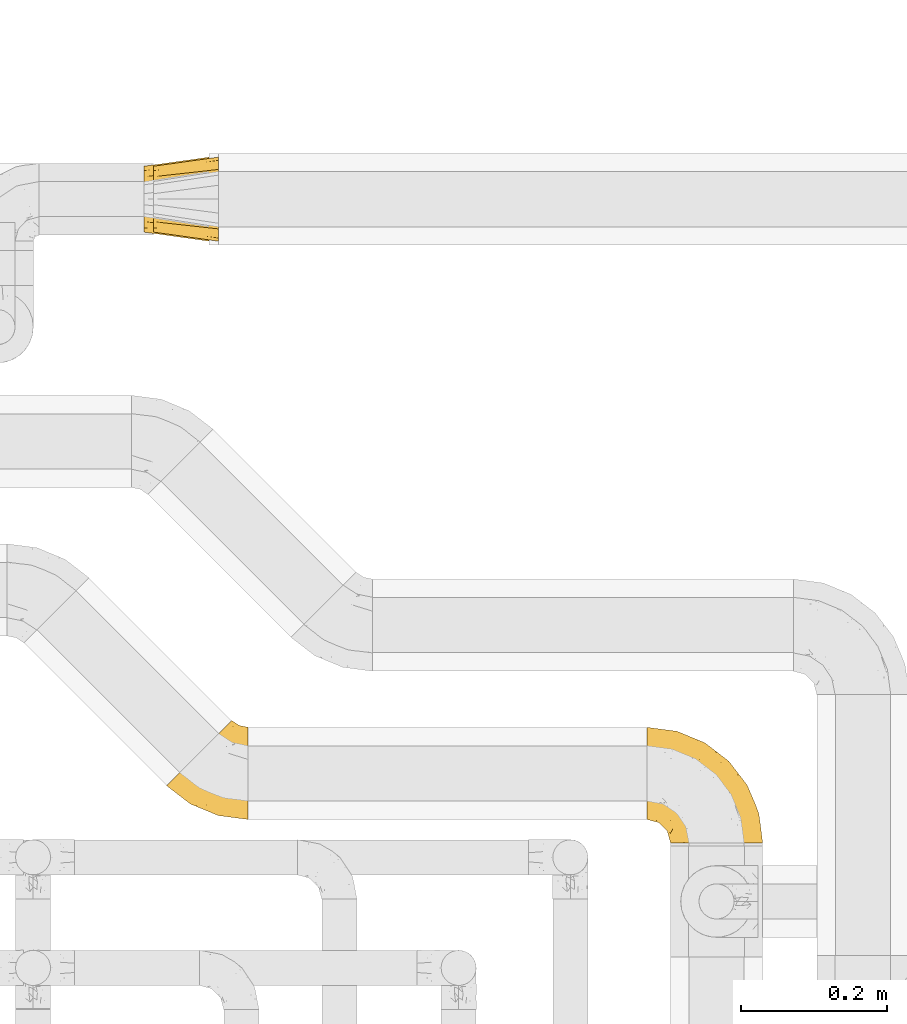
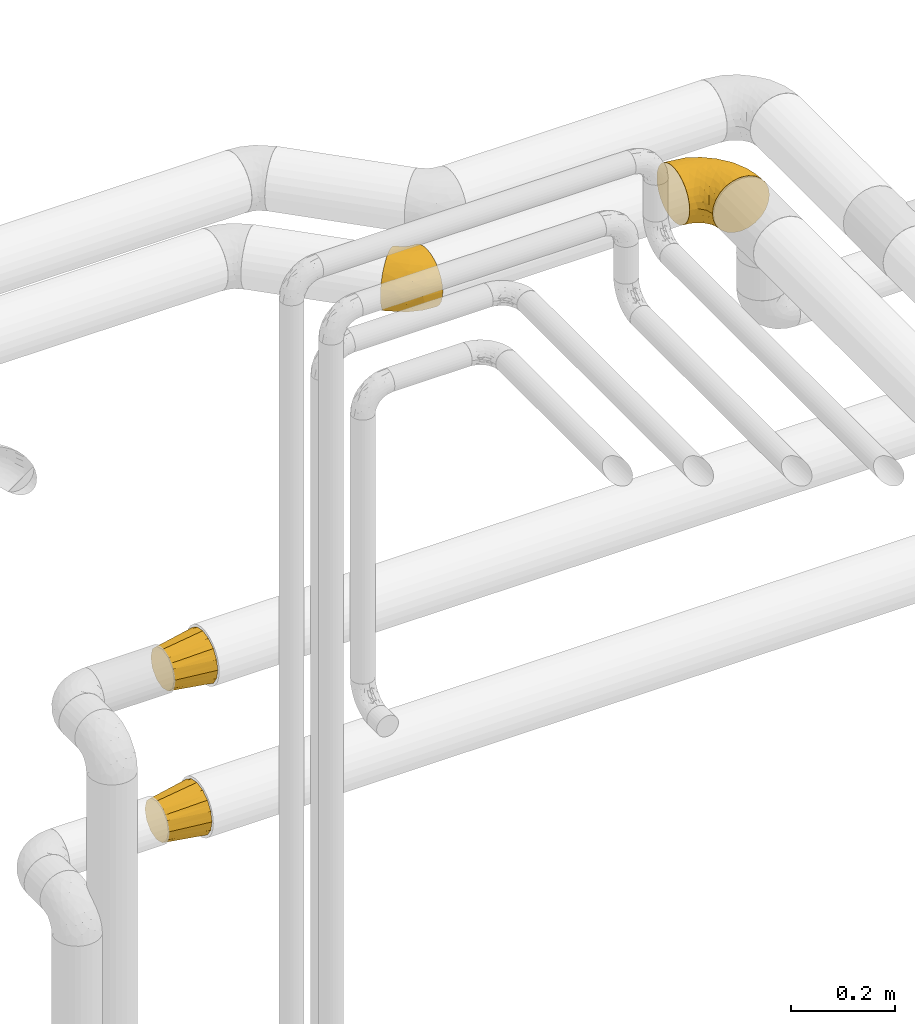
# One storey, part 413 of 827: 4 coverings.
"""IFC2X3 building model written with IfcOpenShell, lengths in millimetres."""

from ifc_helpers import new_model, entity, si_unit, converted_unit, derived_unit, direction, frame, origin, place, context, subcontext, project, spatial, faceted_brep, element, save


model = new_model("IFC2X3")

# Units and contexts
model_context = context("Model", 3, precision=0.01, world=origin(), true_north=direction((6.12303176911189e-17, 1.0)))
body_context = subcontext(model_context, "Body", "Model", "MODEL_VIEW")
ifc_project = project(units=[si_unit("LENGTHUNIT", "METRE", prefix="MILLI"), si_unit("AREAUNIT", "SQUARE_METRE"), si_unit("VOLUMEUNIT", "CUBIC_METRE"), converted_unit("PLANEANGLEUNIT", "DEGREE", entity("IfcRatioMeasure", 0.0174532925199433), si_unit("PLANEANGLEUNIT", "RADIAN"), dimensions=[0, 0, 0, 0, 0, 0, 0]), si_unit("MASSUNIT", "GRAM", prefix="KILO"), derived_unit("MASSDENSITYUNIT", [(si_unit("MASSUNIT", "GRAM", prefix="KILO"), 1), (si_unit("LENGTHUNIT", "METRE"), -3)]), derived_unit("MOMENTOFINERTIAUNIT", [(si_unit("LENGTHUNIT", "METRE"), 4)]), si_unit("TIMEUNIT", "SECOND"), si_unit("FREQUENCYUNIT", "HERTZ"), si_unit("THERMODYNAMICTEMPERATUREUNIT", "DEGREE_CELSIUS"), derived_unit("THERMALTRANSMITTANCEUNIT", [(si_unit("MASSUNIT", "GRAM", prefix="KILO"), 1), (si_unit("THERMODYNAMICTEMPERATUREUNIT", "KELVIN"), -1), (si_unit("TIMEUNIT", "SECOND"), -3)]), derived_unit("VOLUMETRICFLOWRATEUNIT", [(si_unit("LENGTHUNIT", "METRE"), 3), (si_unit("TIMEUNIT", "SECOND"), -1)]), derived_unit("MASSFLOWRATEUNIT", [(si_unit("MASSUNIT", "GRAM", prefix="KILO"), 1), (si_unit("TIMEUNIT", "SECOND"), -1)]), derived_unit("ROTATIONALFREQUENCYUNIT", [(si_unit("TIMEUNIT", "SECOND"), -1)]), si_unit("ELECTRICCURRENTUNIT", "AMPERE"), si_unit("ELECTRICVOLTAGEUNIT", "VOLT"), si_unit("POWERUNIT", "WATT"), si_unit("FORCEUNIT", "NEWTON", prefix="KILO"), si_unit("ILLUMINANCEUNIT", "LUX"), si_unit("LUMINOUSFLUXUNIT", "LUMEN"), si_unit("LUMINOUSINTENSITYUNIT", "CANDELA"), derived_unit("USERDEFINED", [(si_unit("MASSUNIT", "GRAM", prefix="KILO"), -1), (si_unit("LENGTHUNIT", "METRE"), -2), (si_unit("TIMEUNIT", "SECOND"), 3), (si_unit("LUMINOUSFLUXUNIT", "LUMEN"), 1)]), derived_unit("LINEARVELOCITYUNIT", [(si_unit("LENGTHUNIT", "METRE"), 1), (si_unit("TIMEUNIT", "SECOND"), -1)]), si_unit("PRESSUREUNIT", "PASCAL"), derived_unit("USERDEFINED", [(si_unit("LENGTHUNIT", "METRE"), -2), (si_unit("MASSUNIT", "GRAM", prefix="KILO"), 1), (si_unit("TIMEUNIT", "SECOND"), -2)]), derived_unit("LINEARFORCEUNIT", [(si_unit("MASSUNIT", "GRAM", prefix="KILO"), 1), (si_unit("LENGTHUNIT", "METRE"), 1), (si_unit("TIMEUNIT", "SECOND"), -2), (si_unit("LENGTHUNIT", "METRE"), -1)]), derived_unit("PLANARFORCEUNIT", [(si_unit("MASSUNIT", "GRAM", prefix="KILO"), 1), (si_unit("LENGTHUNIT", "METRE"), 1), (si_unit("TIMEUNIT", "SECOND"), -2), (si_unit("LENGTHUNIT", "METRE"), -2)])], contexts=[model_context])

# Site, building, storey
site_placement = place(None, origin())
site = spatial("IfcSite", under=ifc_project, at=site_placement, CompositionType="ELEMENT")
building_placement = place(site_placement, origin())
building = spatial("IfcBuilding", under=site, at=building_placement, CompositionType="ELEMENT")
storey_placement = place(building_placement, frame((0.0, 0.0, 28200.0)))
storey = spatial("IfcBuildingStorey", under=building, at=storey_placement, Name="08", CompositionType="ELEMENT", Elevation=28200.0)

# Coverings
covering_1_placement = place(storey_placement, frame((48548.25, 18259.08, 2935.35)))
element("IfcCovering", 1, at=covering_1_placement, inside=storey, Name=":ADSK_", ObjectType=":ADSK_", PredefinedType="INSULATION", context=body_context, shape_type="Brep", body=[
    faceted_brep([(1.6, 110.62, 126.11), (1.6, 123.95, 121.45), (1.6, 135.9, 113.94), (1.6, 145.89, 103.96), (1.6, 153.4, 92.0), (1.6, 158.06, 78.68), (1.6, 159.65, 64.65), (1.6, 158.06, 50.62), (1.6, 153.4, 37.29), (1.6, 145.89, 25.34), (1.6, 135.91, 15.35), (1.6, 123.95, 7.84), (1.6, 110.63, 3.18), (1.6, 96.6, 1.6), (1.6, 82.57, 3.18), (1.6, 69.24, 7.84), (1.6, 57.29, 15.35), (1.6, 47.3, 25.33), (1.6, 39.79, 37.29), (1.6, 35.13, 50.61), (1.6, 33.55, 64.65), (1.6, 35.13, 78.67), (1.6, 39.79, 92.0), (1.6, 47.3, 103.95), (1.6, 57.28, 113.94), (1.6, 69.24, 121.45), (1.6, 82.56, 126.11), (1.6, 96.6, 127.7), (33.55, 1.6, 64.65), (35.69, 1.6, 48.33), (41.99, 1.6, 33.12), (52.01, 1.6, 20.06), (65.07, 1.6, 10.04), (80.28, 1.6, 3.74), (85.89, 1.6, 3.01), (96.6, 1.6, 1.6), (112.91, 1.6, 3.74), (128.12, 1.6, 10.04), (141.18, 1.6, 20.06), (151.2, 1.6, 33.12), (157.5, 1.6, 48.33), (159.65, 1.6, 64.65), (157.5, 1.6, 80.96), (151.2, 1.6, 96.17), (141.18, 1.6, 109.23), (128.12, 1.6, 119.25), (112.91, 1.6, 125.55), (96.6, 1.6, 127.7), (85.89, 1.6, 126.29), (80.28, 1.6, 125.55), (65.07, 1.6, 119.25), (52.01, 1.6, 109.23), (41.99, 1.6, 96.17), (35.69, 1.6, 80.96), (145.23, 30.13, 101.1), (150.95, 39.4, 86.72), (136.48, 62.65, 98.7), (156.3, 28.52, 75.93), (154.26, 42.5, 64.65), (73.92, 115.57, 113.39), (98.94, 98.94, 111.06), (102.72, 111.29, 96.87), (124.89, 95.5, 84.07), (138.47, 80.62, 64.65), (113.35, 113.35, 64.65), (120.33, 43.71, 119.56), (118.42, 70.76, 112.75), (103.99, 62.71, 122.85), (110.05, 33.16, 125.08), (94.6, 53.41, 126.64), (62.68, 130.65, 105.78), (66.8, 137.68, 93.81), (37.71, 146.84, 96.07), (141.12, 66.58, 87.11), (148.29, 57.7, 75.77), (132.76, 39.88, 111.99), (42.5, 154.26, 64.65), (39.36, 152.07, 83.58), (96.16, 125.54, 80.96), (69.16, 142.81, 78.34), (62.71, 103.99, 122.85), (79.4, 79.4, 125.88), (88.81, 88.81, 120.97), (26.93, 104.86, 126.67), (32.13, 117.38, 122.64), (78.45, 57.43, 127.7), (85.2, 44.19, 127.7), (91.95, 30.95, 127.7), (31.66, 139.96, 107.12), (45.38, 127.03, 115.07), (118.88, 87.17, 102.81), (57.43, 78.45, 127.7), (62.69, 73.2, 127.7), (67.94, 67.94, 127.7), (13.99, 94.63, 127.7), (22.47, 93.29, 127.7), (30.95, 91.95, 127.7), (53.41, 94.6, 126.64), (44.19, 85.2, 127.7), (80.62, 138.47, 64.65), (94.63, 13.99, 127.7), (39.95, 40.46, 113.05), (33.15, 32.36, 101.81), (43.2, 28.71, 108.46), (81.77, 15.53, 126.21), (66.3, 29.06, 122.65), (75.23, 40.03, 126.55), (66.55, 45.36, 125.45), (78.18, 26.46, 126.01), (56.85, 47.56, 123.3), (54.23, 36.28, 118.99), (12.94, 55.57, 113.51), (17.42, 45.02, 104.6), (27.05, 57.55, 118.04), (44.37, 11.56, 101.6), (49.66, 19.2, 109.98), (38.88, 10.07, 92.1), (37.08, 21.04, 96.28), (66.96, 15.52, 121.05), (32.99, 13.84, 79.4), (14.52, 32.67, 79.19), (26.32, 24.86, 80.39), (22.37, 34.31, 93.14), (27.96, 81.47, 126.75), (39.47, 71.26, 125.71), (15.41, 81.64, 126.17), (17.57, 29.26, 64.65), (21.32, 70.65, 123.28), (7.61, 31.93, 64.65), (28.92, 27.99, 91.58), (28.65, 41.71, 107.1), (34.82, 50.14, 116.28), (58.27, 17.57, 116.32), (11.73, 37.62, 90.34), (40.36, 60.48, 122.74), (29.26, 17.57, 64.65), (65.12, 56.96, 126.77), (45.4, 48.98, 119.84), (53.05, 57.29, 124.71), (50.39, 68.25, 126.47), (38.88, 10.07, 37.19), (42.9, 16.58, 27.66), (32.99, 13.84, 49.9), (94.63, 13.99, 1.6), (14.52, 32.67, 50.1), (26.32, 24.86, 48.89), (50.51, 67.81, 2.88), (39.41, 61.09, 6.55), (39.47, 71.26, 3.58), (78.45, 57.43, 1.6), (85.2, 44.19, 1.6), (75.23, 40.03, 2.74), (27.05, 57.55, 11.25), (36.34, 51.01, 11.93), (28.89, 42.79, 21.09), (78.18, 26.46, 3.28), (66.3, 29.06, 6.64), (58.27, 17.57, 12.97), (49.66, 19.2, 19.31), (39.95, 40.46, 16.23), (42.42, 28.84, 21.44), (32.56, 33.48, 26.96), (66.96, 15.52, 8.24), (81.77, 15.53, 3.08), (54.23, 36.28, 10.3), (11.73, 37.62, 38.95), (37.08, 21.04, 33.01), (13.99, 94.63, 1.6), (22.47, 93.29, 1.6), (22.37, 34.31, 36.15), (17.42, 45.03, 24.69), (21.32, 70.65, 6.01), (27.96, 81.47, 2.54), (12.94, 55.58, 15.78), (30.95, 91.95, 1.6), (15.41, 81.64, 3.12), (29.3, 27.86, 37.33), (57.43, 78.45, 1.6), (44.19, 85.2, 1.6), (65.12, 56.96, 2.52), (66.55, 45.36, 3.84), (56.85, 47.57, 5.99), (46.41, 48.27, 9.35), (67.94, 67.94, 1.6), (53.04, 57.3, 4.58), (91.95, 30.95, 1.6), (136.48, 62.65, 30.59), (145.23, 30.13, 28.19), (132.76, 39.88, 17.3), (120.33, 43.71, 9.73), (150.95, 39.4, 42.57), (149.01, 55.79, 53.51), (156.33, 28.41, 53.42), (94.6, 53.41, 2.65), (26.93, 104.86, 2.62), (32.14, 117.39, 6.66), (62.71, 103.99, 6.44), (96.16, 125.54, 48.33), (102.72, 111.29, 32.42), (66.79, 137.69, 35.49), (53.41, 94.6, 2.65), (79.4, 79.4, 3.41), (110.05, 33.16, 4.21), (140.44, 68.78, 43.07), (62.68, 130.66, 23.52), (31.66, 139.97, 22.18), (29.31, 148.6, 33.1), (73.92, 115.58, 15.9), (45.39, 127.03, 14.23), (118.42, 70.76, 16.54), (124.89, 95.5, 45.22), (103.99, 62.71, 6.44), (88.81, 88.81, 8.33), (98.94, 98.94, 18.23), (122.85, 89.09, 32.99), (138.38, 78.72, 53.35), (69.18, 142.21, 48.76), (39.36, 152.07, 45.72)], [[[0, 1, 2, 3, 4, 5, 6, 7, 8, 9, 10, 11, 12, 13, 14, 15, 16, 17, 18, 19, 20, 21, 22, 23, 24, 25, 26, 27]], [[28, 29, 30, 31, 32, 33, 34, 35, 36, 37, 38, 39, 40, 41, 42, 43, 44, 45, 46, 47, 48, 49, 50, 51, 52, 53]], [[54, 55, 56]], [[57, 41, 58]], [[59, 60, 61]], [[62, 63, 64]], [[65, 66, 67]], [[68, 67, 69]], [[70, 71, 72]], [[55, 73, 56]], [[43, 42, 55]], [[55, 74, 73]], [[44, 75, 45]], [[44, 43, 54]], [[76, 5, 77]], [[71, 78, 79]], [[45, 75, 65]], [[46, 68, 47]], [[80, 81, 82]], [[0, 83, 84]], [[69, 85, 86, 87]], [[69, 81, 85]], [[84, 1, 0]], [[2, 88, 3]], [[4, 3, 72]], [[44, 54, 75]], [[5, 4, 77]], [[89, 2, 1]], [[72, 3, 88]], [[5, 76, 6]], [[70, 88, 89]], [[68, 65, 67]], [[88, 2, 89]], [[56, 90, 66]], [[64, 78, 62]], [[81, 91, 92, 93, 85]], [[83, 27, 94, 95, 96]], [[62, 61, 90]], [[97, 96, 98, 91]], [[80, 97, 81]], [[42, 57, 55]], [[62, 78, 61]], [[84, 89, 1]], [[78, 64, 99]], [[57, 74, 55]], [[76, 77, 79]], [[77, 72, 71]], [[82, 81, 67]], [[97, 83, 96]], [[80, 89, 84]], [[79, 78, 99]], [[71, 70, 61]], [[81, 97, 91]], [[83, 80, 84]], [[68, 87, 100, 47]], [[81, 69, 67]], [[68, 69, 87]], [[65, 46, 45]], [[65, 68, 46]], [[66, 65, 75]], [[56, 66, 75]], [[66, 60, 82]], [[71, 61, 78]], [[60, 66, 90]], [[83, 97, 80]], [[27, 83, 0]], [[59, 70, 89]], [[70, 59, 61]], [[89, 80, 59]], [[82, 59, 80]], [[55, 54, 43]], [[75, 54, 56]], [[66, 82, 67]], [[59, 82, 60]], [[41, 57, 42]], [[74, 57, 58]], [[58, 63, 74]], [[62, 74, 63]], [[74, 62, 73]], [[62, 56, 73]], [[4, 72, 77]], [[70, 72, 88]], [[76, 79, 99]], [[71, 79, 77]], [[62, 90, 56]], [[60, 90, 61]], [[101, 102, 103]], [[100, 87, 104]], [[105, 106, 107]], [[108, 104, 87]], [[107, 109, 110]], [[108, 87, 86]], [[111, 112, 113]], [[114, 51, 115]], [[116, 114, 117]], [[51, 50, 118]], [[119, 28, 53]], [[120, 121, 122]], [[98, 123, 124]], [[125, 96, 95]], [[116, 53, 52]], [[126, 121, 120]], [[104, 108, 118]], [[98, 124, 91]], [[25, 24, 127]], [[120, 128, 126]], [[122, 129, 102]], [[95, 94, 27, 26]], [[122, 102, 130]], [[125, 127, 123]], [[24, 111, 127]], [[21, 20, 128]], [[112, 130, 131]], [[48, 47, 100, 49]], [[132, 110, 115]], [[23, 111, 24]], [[129, 119, 117]], [[120, 133, 21]], [[112, 23, 22]], [[134, 113, 131]], [[121, 126, 135]], [[133, 112, 22]], [[128, 120, 21]], [[132, 51, 118]], [[120, 122, 133]], [[119, 121, 135]], [[129, 117, 102]], [[125, 26, 25]], [[26, 125, 95]], [[127, 125, 25]], [[28, 119, 135]], [[119, 53, 116]], [[127, 113, 124]], [[96, 125, 123]], [[112, 131, 113]], [[101, 103, 110]], [[85, 93, 136]], [[124, 123, 127]], [[98, 96, 123]], [[112, 111, 23]], [[127, 111, 113]], [[112, 133, 122]], [[21, 133, 22]], [[107, 110, 105]], [[110, 109, 137]], [[86, 106, 108]], [[138, 109, 136]], [[105, 118, 108]], [[107, 106, 85]], [[104, 50, 49]], [[124, 134, 139]], [[138, 93, 92]], [[92, 91, 139]], [[100, 104, 49]], [[118, 105, 132]], [[104, 118, 50]], [[110, 132, 105]], [[51, 132, 115]], [[108, 106, 105]], [[85, 106, 86]], [[114, 116, 52]], [[119, 116, 117]], [[51, 114, 52]], [[114, 115, 103]], [[117, 114, 103]], [[130, 102, 101]], [[117, 103, 102]], [[110, 103, 115]], [[130, 101, 131]], [[122, 130, 112]], [[101, 137, 131]], [[113, 134, 124]], [[137, 134, 131]], [[124, 139, 91]], [[134, 138, 139]], [[92, 139, 138]], [[110, 137, 101]], [[134, 137, 138]], [[136, 109, 107]], [[137, 109, 138]], [[85, 136, 107]], [[138, 136, 93]], [[122, 121, 129]], [[129, 121, 119]], [[30, 140, 141]], [[30, 29, 140]], [[28, 135, 142]], [[143, 35, 34, 33]], [[19, 144, 128]], [[126, 145, 135]], [[146, 147, 148]], [[149, 150, 151]], [[152, 153, 154]], [[155, 156, 151]], [[157, 31, 158]], [[159, 160, 161]], [[32, 162, 163]], [[158, 31, 30]], [[157, 164, 156]], [[126, 144, 145]], [[126, 128, 144]], [[18, 165, 19]], [[141, 166, 160]], [[14, 13, 167, 168]], [[163, 143, 33]], [[169, 165, 170]], [[18, 17, 170]], [[153, 159, 154]], [[142, 135, 145]], [[148, 171, 172]], [[159, 161, 154]], [[171, 152, 173]], [[173, 17, 16]], [[16, 15, 171]], [[158, 160, 164]], [[174, 175, 168]], [[173, 170, 17]], [[19, 128, 20]], [[174, 172, 175]], [[165, 169, 144]], [[162, 157, 156]], [[175, 172, 171]], [[144, 169, 145]], [[176, 169, 161]], [[166, 140, 142]], [[175, 171, 15]], [[168, 175, 14]], [[14, 175, 15]], [[142, 145, 176]], [[28, 142, 29]], [[148, 177, 146]], [[148, 178, 177]], [[152, 171, 148]], [[179, 180, 181]], [[164, 180, 156]], [[174, 178, 172]], [[148, 172, 178]], [[171, 173, 16]], [[170, 173, 152]], [[19, 165, 144]], [[170, 165, 18]], [[153, 182, 159]], [[146, 183, 184]], [[181, 180, 164]], [[180, 151, 156]], [[163, 155, 185]], [[155, 150, 185]], [[162, 156, 155]], [[143, 163, 185]], [[180, 179, 149]], [[32, 163, 33]], [[163, 162, 155]], [[31, 162, 32]], [[31, 157, 162]], [[164, 157, 158]], [[149, 151, 180]], [[155, 151, 150]], [[142, 140, 29]], [[141, 140, 166]], [[176, 145, 169]], [[30, 141, 158]], [[164, 160, 159]], [[158, 141, 160]], [[166, 161, 160]], [[154, 169, 170]], [[169, 154, 161]], [[152, 154, 170]], [[147, 152, 148]], [[153, 147, 182]], [[181, 182, 184]], [[164, 159, 182]], [[161, 166, 176]], [[142, 176, 166]], [[183, 146, 177]], [[184, 182, 147]], [[184, 147, 146]], [[152, 147, 153]], [[182, 181, 164]], [[179, 184, 183]], [[184, 179, 181]], [[149, 179, 183]], [[186, 187, 188]], [[37, 36, 189]], [[190, 191, 192]], [[193, 185, 150, 149]], [[194, 195, 196]], [[197, 198, 199]], [[200, 201, 177]], [[193, 202, 185]], [[203, 190, 186]], [[202, 189, 36]], [[41, 40, 192]], [[204, 205, 199]], [[9, 8, 206]], [[187, 190, 39]], [[40, 39, 190]], [[38, 37, 188]], [[207, 208, 204]], [[202, 35, 143, 185]], [[39, 38, 187]], [[195, 11, 208]], [[201, 149, 183, 177]], [[188, 189, 209]], [[197, 64, 210]], [[186, 188, 209]], [[13, 12, 194]], [[211, 201, 212]], [[12, 11, 195]], [[193, 201, 211]], [[212, 201, 196]], [[10, 208, 11]], [[213, 214, 209]], [[64, 63, 215]], [[216, 197, 199]], [[8, 217, 206]], [[7, 217, 8]], [[203, 191, 190]], [[7, 6, 76]], [[208, 205, 204]], [[205, 10, 9]], [[199, 205, 206]], [[7, 76, 217]], [[205, 208, 10]], [[216, 76, 99]], [[200, 177, 178, 174]], [[64, 197, 99]], [[63, 58, 191]], [[208, 196, 195]], [[196, 200, 194]], [[198, 197, 210]], [[216, 199, 217]], [[201, 193, 149]], [[202, 193, 211]], [[202, 211, 189]], [[35, 202, 36]], [[211, 212, 209]], [[37, 189, 188]], [[211, 209, 189]], [[213, 198, 214]], [[200, 174, 194]], [[201, 200, 196]], [[214, 198, 210]], [[213, 207, 198]], [[194, 174, 168, 167, 13]], [[195, 194, 12]], [[198, 204, 199]], [[204, 198, 207]], [[212, 207, 213]], [[196, 208, 207]], [[188, 187, 38]], [[190, 187, 186]], [[207, 212, 196]], [[209, 212, 213]], [[214, 203, 186]], [[191, 215, 63]], [[191, 203, 215]], [[192, 191, 58]], [[41, 192, 58]], [[190, 192, 40]], [[203, 210, 215]], [[64, 215, 210]], [[199, 206, 217]], [[9, 206, 205]], [[76, 216, 217]], [[99, 197, 216]], [[203, 214, 210]], [[209, 214, 186]]]),
])
covering_2_placement = place(storey_placement, frame((47890.84, 18291.03, 2935.35)))
element("IfcCovering", 2, at=covering_2_placement, inside=storey, Name=":ADSK_", ObjectType=":ADSK_", PredefinedType="INSULATION", context=body_context, shape_type="Brep", body=[
    faceted_brep([(113.35, 127.7, 64.65), (113.35, 126.11, 78.67), (113.35, 121.45, 92.0), (113.35, 113.94, 103.95), (113.35, 103.96, 113.94), (113.35, 92.0, 121.45), (113.35, 78.68, 126.11), (113.35, 64.65, 127.7), (113.35, 50.62, 126.11), (113.35, 37.29, 121.45), (113.35, 25.34, 113.94), (113.35, 15.35, 103.96), (113.35, 7.84, 92.0), (113.35, 3.18, 78.68), (113.35, 1.6, 64.65), (113.35, 3.18, 50.62), (113.35, 7.84, 37.29), (113.35, 15.35, 25.34), (113.35, 25.33, 15.35), (113.35, 37.29, 7.84), (113.35, 50.61, 3.18), (113.35, 64.65, 1.6), (113.35, 78.67, 3.18), (113.35, 92.0, 7.84), (113.35, 103.95, 15.35), (113.35, 113.94, 25.33), (113.35, 121.45, 37.29), (113.35, 126.11, 50.61), (90.76, 137.05, 64.65), (89.24, 135.53, 48.33), (84.79, 131.08, 33.12), (77.7, 124.0, 20.06), (68.47, 114.76, 10.04), (57.72, 104.01, 3.74), (46.18, 92.47, 1.6), (34.64, 80.93, 3.74), (23.89, 70.18, 10.04), (14.65, 60.95, 20.06), (7.57, 53.86, 33.12), (3.11, 49.41, 48.33), (1.6, 47.89, 64.65), (3.11, 49.41, 80.96), (7.57, 53.86, 96.17), (14.65, 60.95, 109.23), (23.89, 70.18, 119.25), (34.64, 80.93, 125.55), (46.18, 92.47, 127.7), (57.72, 104.01, 125.55), (68.47, 114.76, 119.25), (77.7, 124.0, 109.23), (84.79, 131.08, 96.17), (89.24, 135.53, 80.96), (82.25, 22.45, 108.1), (34.33, 22.77, 64.65), (21.83, 33.18, 80.19), (32.11, 38.64, 102.05), (72.45, 6.98, 64.65), (42.98, 20.62, 81.27), (69.69, 54.22, 124.73), (45.61, 59.86, 122.26), (78.83, 8.74, 84.6), (55.06, 37.39, 113.02), (65.85, 77.37, 127.7), (56.15, 84.82, 127.7), (86.72, 13.12, 97.32), (56.96, 21.15, 96.3), (86.58, 32.48, 117.12), (26.66, 34.19, 90.52), (100.89, 66.29, 127.7), (88.77, 67.88, 127.7), (77.31, 72.63, 127.7), (65.07, 43.92, 119.88), (102.7, 95.22, 120.26), (100.29, 80.66, 125.9), (69.96, 95.96, 125.09), (81.48, 107.27, 117.94), (100.72, 107.42, 112.32), (90.26, 93.57, 122.53), (96.84, 118.48, 102.2), (86.87, 121.19, 105.16), (91.1, 111.65, 111.58), (106.05, 117.49, 99.98), (95.88, 131.99, 74.42), (101.77, 125.2, 87.77), (104.32, 127.93, 75.98), (87.42, 80.56, 126.59), (79.05, 88.58, 125.61), (92.68, 128.43, 90.37), (101.13, 130.13, 64.65), (101.77, 125.19, 41.51), (100.72, 107.41, 16.97), (97.53, 130.44, 52.07), (81.48, 107.27, 11.35), (69.96, 95.96, 4.2), (93.01, 126.18, 35.35), (96.84, 118.48, 27.09), (56.15, 84.82, 1.6), (87.42, 80.56, 2.7), (88.77, 67.88, 1.6), (77.31, 72.63, 1.6), (102.7, 95.22, 9.03), (90.26, 93.56, 6.76), (77.09, 85.62, 2.86), (79.18, 96.8, 6.13), (86.87, 121.19, 24.13), (91.09, 111.65, 17.7), (100.29, 80.66, 3.39), (106.05, 117.49, 29.31), (100.89, 66.29, 1.6), (65.85, 77.37, 1.6), (69.69, 54.22, 4.56), (45.61, 59.86, 7.03), (82.25, 22.44, 21.19), (55.07, 37.39, 16.27), (86.58, 32.48, 12.17), (86.72, 13.12, 31.97), (56.96, 21.15, 33.0), (32.11, 38.63, 27.24), (21.84, 33.18, 49.11), (26.66, 34.19, 38.77), (78.83, 8.73, 44.69), (42.98, 20.62, 48.02), (65.07, 43.91, 9.41)], [[[0, 1, 2, 3, 4, 5, 6, 7, 8, 9, 10, 11, 12, 13, 14, 15, 16, 17, 18, 19, 20, 21, 22, 23, 24, 25, 26, 27]], [[28, 29, 30, 31, 32, 33, 34, 35, 36, 37, 38, 39, 40, 41, 42, 43, 44, 45, 46, 47, 48, 49, 50, 51]], [[52, 11, 10]], [[40, 53, 54]], [[42, 55, 43]], [[53, 56, 57]], [[9, 8, 58]], [[45, 59, 58]], [[56, 13, 60]], [[61, 44, 43]], [[45, 62, 63, 46]], [[62, 45, 58]], [[59, 45, 44]], [[64, 52, 65]], [[55, 61, 43]], [[61, 65, 52]], [[60, 57, 56]], [[60, 65, 57]], [[52, 10, 66]], [[64, 12, 11]], [[64, 60, 12]], [[13, 56, 14]], [[61, 55, 65]], [[67, 55, 42]], [[54, 67, 41]], [[61, 52, 66]], [[66, 10, 9]], [[8, 7, 68, 69]], [[58, 69, 70, 62]], [[58, 8, 69]], [[60, 64, 65]], [[52, 64, 11]], [[58, 59, 71]], [[54, 57, 67]], [[58, 66, 9]], [[60, 13, 12]], [[41, 67, 42]], [[65, 55, 67]], [[65, 67, 57]], [[40, 54, 41]], [[53, 57, 54]], [[44, 61, 59]], [[58, 71, 66]], [[59, 61, 71]], [[61, 66, 71]], [[72, 73, 5]], [[62, 74, 63]], [[48, 75, 49]], [[63, 74, 47]], [[75, 48, 74]], [[72, 76, 77]], [[78, 79, 80]], [[81, 3, 2]], [[82, 28, 51]], [[83, 84, 82]], [[73, 77, 85]], [[86, 62, 70]], [[83, 87, 78]], [[50, 87, 51]], [[86, 75, 74]], [[68, 73, 69]], [[5, 4, 72]], [[73, 6, 5]], [[74, 48, 47]], [[73, 68, 6]], [[80, 77, 76]], [[69, 85, 70]], [[81, 76, 3]], [[88, 84, 0]], [[84, 83, 1]], [[1, 83, 2]], [[3, 76, 4]], [[50, 49, 79]], [[83, 78, 81]], [[80, 76, 78]], [[73, 72, 77]], [[76, 72, 4]], [[85, 86, 70]], [[68, 7, 6]], [[73, 85, 69]], [[86, 85, 77]], [[75, 86, 77]], [[86, 74, 62]], [[47, 46, 63]], [[83, 81, 2]], [[76, 81, 78]], [[75, 79, 49]], [[87, 79, 78]], [[79, 75, 80]], [[77, 80, 75]], [[0, 84, 1]], [[82, 84, 88]], [[28, 82, 88]], [[82, 51, 87]], [[87, 50, 79]], [[82, 87, 83]], [[27, 26, 89]], [[25, 24, 90]], [[88, 91, 28]], [[32, 92, 93]], [[94, 89, 95]], [[94, 29, 91]], [[93, 96, 33]], [[97, 98, 99]], [[24, 23, 100]], [[101, 102, 103]], [[104, 95, 105]], [[93, 33, 32]], [[100, 90, 24]], [[102, 97, 99]], [[91, 27, 89]], [[97, 106, 98]], [[26, 107, 89]], [[93, 92, 103]], [[90, 95, 107]], [[31, 92, 32]], [[31, 30, 104]], [[107, 26, 25]], [[23, 22, 106]], [[101, 97, 102]], [[89, 94, 91]], [[31, 104, 92]], [[98, 106, 108]], [[106, 22, 108]], [[100, 106, 101]], [[101, 92, 105]], [[106, 100, 23]], [[27, 88, 0]], [[90, 100, 101]], [[22, 21, 108]], [[93, 102, 109]], [[106, 97, 101]], [[109, 102, 99]], [[102, 93, 103]], [[96, 93, 109]], [[96, 34, 33]], [[101, 103, 92]], [[90, 107, 25]], [[89, 107, 95]], [[94, 104, 30]], [[95, 90, 105]], [[101, 105, 90]], [[92, 104, 105]], [[104, 94, 95]], [[29, 94, 30]], [[28, 91, 29]], [[27, 91, 88]], [[35, 110, 111]], [[112, 113, 114]], [[35, 34, 96, 109]], [[112, 114, 18]], [[112, 115, 116]], [[117, 113, 116]], [[39, 118, 40]], [[116, 119, 117]], [[120, 121, 116]], [[113, 117, 37]], [[36, 113, 37]], [[38, 117, 119]], [[119, 116, 121]], [[20, 19, 110]], [[110, 109, 99, 98]], [[122, 111, 110]], [[20, 98, 108, 21]], [[37, 117, 38]], [[112, 18, 17]], [[39, 119, 118]], [[116, 113, 112]], [[110, 35, 109]], [[119, 39, 38]], [[114, 19, 18]], [[121, 120, 56]], [[115, 17, 16]], [[15, 14, 56]], [[15, 56, 120]], [[110, 19, 114]], [[115, 120, 116]], [[121, 56, 53]], [[15, 120, 16]], [[115, 112, 17]], [[20, 110, 98]], [[120, 115, 16]], [[35, 111, 36]], [[119, 121, 118]], [[121, 53, 118]], [[40, 118, 53]], [[122, 110, 114]], [[113, 36, 111]], [[114, 113, 122]], [[113, 111, 122]]]),
])
covering_3_placement = place(storey_placement, frame((47874.3, 19082.13, 1590.9)))
element("IfcCovering", 3, at=covering_3_placement, inside=storey, Name=":ADSK_", ObjectType=":ADSK_", PredefinedType="INSULATION", context=body_context, shape_type="Brep", body=[
    faceted_brep([(89.0, 37.09, 5.97), (89.0, 48.09, 3.78), (89.0, 59.1, 1.6), (89.0, 70.1, 3.78), (89.0, 81.1, 5.97), (89.0, 90.43, 12.2), (89.0, 99.75, 18.44), (89.0, 105.99, 27.76), (89.0, 112.22, 37.09), (89.0, 114.41, 48.09), (89.0, 116.6, 59.1), (89.0, 114.41, 70.1), (89.0, 112.22, 81.1), (89.0, 105.99, 90.43), (89.0, 99.75, 99.75), (89.0, 90.43, 105.99), (89.0, 81.1, 112.22), (89.0, 70.1, 114.41), (89.0, 59.1, 116.6), (89.0, 48.09, 114.41), (89.0, 37.09, 112.22), (89.0, 27.76, 105.99), (89.0, 18.44, 99.75), (89.0, 12.2, 90.43), (89.0, 5.97, 81.1), (89.0, 3.78, 70.1), (89.0, 1.6, 59.1), (89.0, 3.78, 48.09), (89.0, 5.97, 37.09), (89.0, 12.2, 27.76), (89.0, 18.44, 18.44), (89.0, 27.76, 12.2), (0.0, 81.6, 98.07), (0.0, 89.83, 89.83), (0.0, 98.07, 81.6), (0.0, 101.08, 70.35), (0.0, 104.1, 59.1), (0.0, 101.08, 47.85), (0.0, 98.07, 36.6), (0.0, 89.83, 28.36), (0.0, 81.6, 20.12), (0.0, 70.35, 17.11), (0.0, 59.1, 14.1), (0.0, 47.85, 17.11), (0.0, 36.6, 20.12), (0.0, 28.36, 28.36), (0.0, 20.12, 36.6), (0.0, 17.11, 47.85), (0.0, 14.1, 59.1), (0.0, 17.11, 70.35), (0.0, 20.12, 81.6), (0.0, 28.36, 89.83), (0.0, 36.6, 98.07), (0.0, 47.85, 101.08), (0.0, 59.1, 104.1), (0.0, 70.35, 101.08)], [[[0, 1, 2, 3, 4, 5, 6, 7, 8, 9, 10, 11, 12, 13, 14, 15, 16, 17, 18, 19, 20, 21, 22, 23, 24, 25, 26, 27, 28, 29, 30, 31]], [[32, 33, 34, 35, 36, 37, 38, 39, 40, 41, 42, 43, 44, 45, 46, 47, 48, 49, 50, 51, 52, 53, 54, 55]], [[27, 26, 48]], [[44, 31, 45]], [[45, 29, 46]], [[48, 47, 27]], [[30, 45, 31]], [[44, 0, 31]], [[29, 45, 30]], [[42, 1, 43]], [[29, 28, 46]], [[47, 46, 28]], [[1, 42, 2]], [[0, 44, 43]], [[1, 0, 43]], [[47, 28, 27]], [[3, 2, 42]], [[38, 7, 39]], [[39, 5, 40]], [[42, 41, 3]], [[6, 39, 7]], [[38, 8, 7]], [[5, 39, 6]], [[36, 9, 37]], [[5, 4, 40]], [[41, 40, 4]], [[9, 36, 10]], [[8, 38, 37]], [[9, 8, 37]], [[41, 4, 3]], [[11, 10, 36]], [[32, 15, 33]], [[33, 13, 34]], [[36, 35, 11]], [[14, 33, 15]], [[32, 16, 15]], [[13, 33, 14]], [[54, 17, 55]], [[13, 12, 34]], [[35, 34, 12]], [[17, 54, 18]], [[16, 32, 55]], [[17, 16, 55]], [[35, 12, 11]], [[19, 18, 54]], [[50, 23, 51]], [[51, 21, 52]], [[54, 53, 19]], [[22, 51, 23]], [[50, 24, 23]], [[21, 51, 22]], [[48, 25, 49]], [[21, 20, 52]], [[53, 52, 20]], [[25, 48, 26]], [[24, 50, 49]], [[25, 24, 49]], [[53, 20, 19]]]),
])
covering_4_placement = place(storey_placement, frame((47861.3, 19082.13, 1240.9)))
element("IfcCovering", 4, at=covering_4_placement, inside=storey, Name=":ADSK_", ObjectType=":ADSK_", PredefinedType="INSULATION", context=body_context, shape_type="Brep", body=[
    faceted_brep([(0.0, 104.1, 59.1), (0.0, 101.08, 47.85), (0.0, 98.07, 36.6), (0.0, 89.83, 28.36), (0.0, 81.6, 20.12), (0.0, 70.35, 17.11), (0.0, 59.1, 14.1), (0.0, 47.85, 17.11), (0.0, 36.6, 20.12), (0.0, 28.36, 28.36), (0.0, 20.12, 36.6), (0.0, 17.11, 47.85), (0.0, 14.1, 59.1), (0.0, 17.11, 70.35), (0.0, 20.12, 81.6), (0.0, 28.36, 89.83), (0.0, 36.6, 98.07), (0.0, 47.85, 101.08), (0.0, 59.1, 104.1), (0.0, 70.35, 101.08), (0.0, 81.6, 98.07), (0.0, 89.83, 89.83), (0.0, 98.07, 81.6), (0.0, 101.08, 70.35), (89.0, 5.97, 81.1), (89.0, 3.78, 70.1), (89.0, 1.6, 59.1), (89.0, 3.78, 48.09), (89.0, 5.97, 37.09), (89.0, 12.2, 27.76), (89.0, 18.44, 18.44), (89.0, 27.76, 12.2), (89.0, 37.09, 5.97), (89.0, 48.09, 3.78), (89.0, 59.1, 1.6), (89.0, 70.1, 3.78), (89.0, 81.1, 5.97), (89.0, 90.43, 12.2), (89.0, 99.75, 18.44), (89.0, 105.99, 27.76), (89.0, 112.22, 37.09), (89.0, 114.41, 48.09), (89.0, 116.6, 59.1), (89.0, 114.41, 70.1), (89.0, 112.22, 81.1), (89.0, 105.99, 90.43), (89.0, 99.75, 99.75), (89.0, 90.43, 105.99), (89.0, 81.1, 112.22), (89.0, 70.1, 114.41), (89.0, 59.1, 116.6), (89.0, 48.09, 114.41), (89.0, 37.09, 112.22), (89.0, 27.76, 105.99), (89.0, 18.44, 99.75), (89.0, 12.2, 90.43)], [[[0, 1, 2, 3, 4, 5, 6, 7, 8, 9, 10, 11, 12, 13, 14, 15, 16, 17, 18, 19, 20, 21, 22, 23]], [[24, 25, 26, 27, 28, 29, 30, 31, 32, 33, 34, 35, 36, 37, 38, 39, 40, 41, 42, 43, 44, 45, 46, 47, 48, 49, 50, 51, 52, 53, 54, 55]], [[35, 34, 6]], [[2, 40, 39]], [[37, 36, 4]], [[37, 4, 3]], [[2, 39, 3]], [[37, 3, 38]], [[41, 40, 1]], [[6, 5, 35]], [[39, 38, 3]], [[0, 41, 1]], [[5, 4, 36]], [[41, 0, 42]], [[40, 2, 1]], [[5, 36, 35]], [[27, 26, 12]], [[8, 32, 31]], [[29, 28, 10]], [[29, 10, 9]], [[8, 31, 9]], [[29, 9, 30]], [[33, 32, 7]], [[12, 11, 27]], [[31, 30, 9]], [[6, 33, 7]], [[11, 10, 28]], [[33, 6, 34]], [[32, 8, 7]], [[11, 28, 27]], [[51, 50, 18]], [[14, 24, 55]], [[53, 52, 16]], [[53, 16, 15]], [[14, 55, 15]], [[53, 15, 54]], [[25, 24, 13]], [[18, 17, 51]], [[55, 54, 15]], [[12, 25, 13]], [[17, 16, 52]], [[25, 12, 26]], [[24, 14, 13]], [[17, 52, 51]], [[43, 42, 0]], [[20, 48, 47]], [[45, 44, 22]], [[45, 22, 21]], [[20, 47, 21]], [[45, 21, 46]], [[49, 48, 19]], [[0, 23, 43]], [[47, 46, 21]], [[18, 49, 19]], [[23, 22, 44]], [[49, 18, 50]], [[48, 20, 19]], [[23, 44, 43]]]),
])

save(model, "model.ifc")
